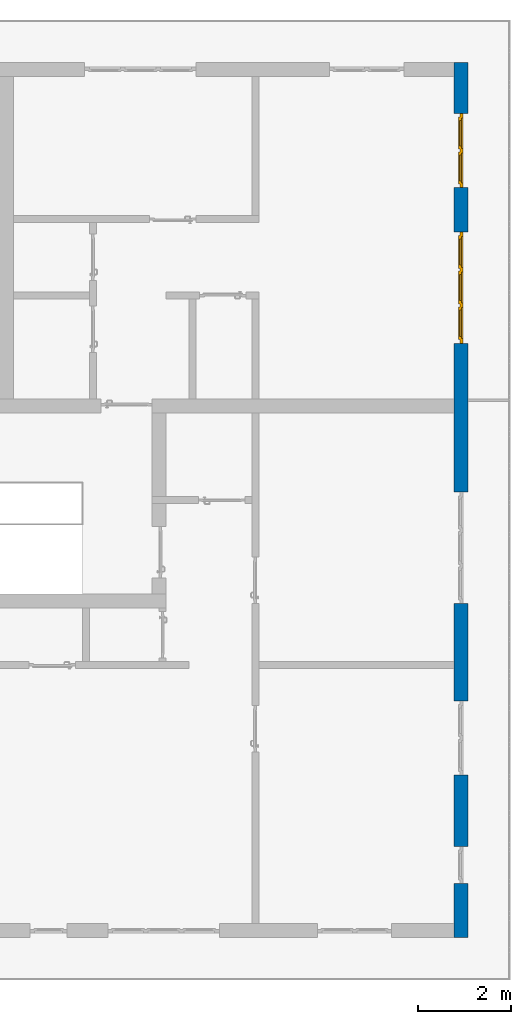
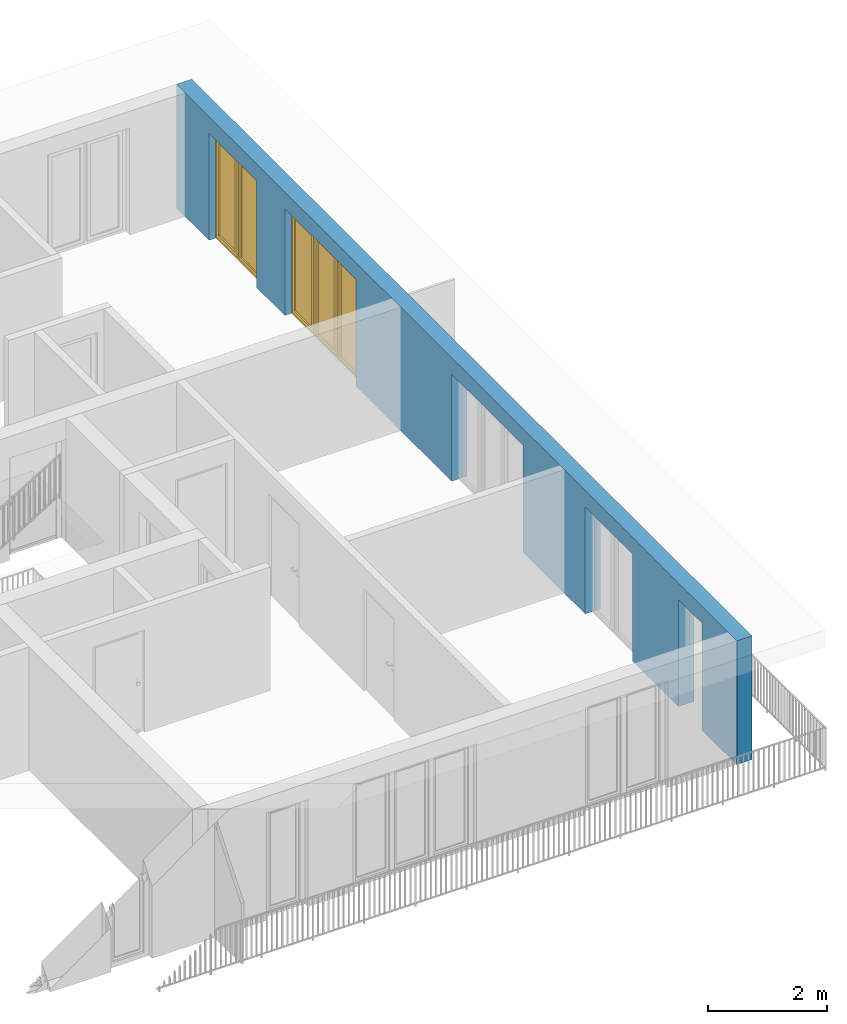
# One storey, part 20 of 54: 2 windows, 1 wall, 5 openings.
"""IFC4 building model written with IfcOpenShell, lengths in metres."""

from ifc_helpers import new_model, entity, si_unit, converted_unit, derived_unit, direction, frame, origin_with_axes, place, context, subcontext, project, spatial, polygons, source, transform, mapped, material, type_object, element, fill, save


model = new_model("IFC4")

# Units and contexts
model_context = context("Model", 3, precision=1e-05, world=origin_with_axes(), true_north=direction((0.0, 1.0)))
body_context = subcontext(model_context, "Body", "Model", "MODEL_VIEW")
ifc_project = project(units=[si_unit("LENGTHUNIT", "METRE"), si_unit("AREAUNIT", "SQUARE_METRE"), si_unit("VOLUMEUNIT", "CUBIC_METRE"), converted_unit("PLANEANGLEUNIT", "DEGREE", entity("IfcPlaneAngleMeasure", 0.0174532925199), si_unit("PLANEANGLEUNIT", "RADIAN"), dimensions=[0, 0, 0, 0, 0, 0, 0]), converted_unit("TIMEUNIT", "Year", entity("IfcTimeMeasure", 31556926.0), si_unit("TIMEUNIT", "SECOND"), dimensions=[0, 0, 1, 0, 0, 0, 0]), si_unit("MASSUNIT", "GRAM", prefix="KILO"), si_unit("THERMODYNAMICTEMPERATUREUNIT", "DEGREE_CELSIUS"), si_unit("LUMINOUSINTENSITYUNIT", "LUMEN"), si_unit("ENERGYUNIT", "JOULE", prefix="MEGA"), derived_unit("THERMALCONDUCTANCEUNIT", [(si_unit("POWERUNIT", "WATT"), 1), (si_unit("LENGTHUNIT", "METRE"), -1), (si_unit("THERMODYNAMICTEMPERATUREUNIT", "KELVIN"), -1)]), derived_unit("SPECIFICHEATCAPACITYUNIT", [(si_unit("ENERGYUNIT", "JOULE"), 1), (si_unit("MASSUNIT", "GRAM", prefix="KILO"), -1), (si_unit("THERMODYNAMICTEMPERATUREUNIT", "KELVIN"), -1)]), derived_unit("MASSDENSITYUNIT", [(si_unit("MASSUNIT", "GRAM", prefix="KILO"), 1), (si_unit("VOLUMEUNIT", "CUBIC_METRE"), -1)])], contexts=[model_context])

# Site, building, storey
site_placement = place(None, origin_with_axes())
site = spatial("IfcSite", under=ifc_project, at=site_placement, CompositionType="ELEMENT")
building_placement = place(site_placement, origin_with_axes())
building = spatial("IfcBuilding", under=site, at=building_placement, CompositionType="ELEMENT")
storey_placement = place(building_placement, frame((0.0, 0.0, 6.29), z_axis=(0.0, 0.0, 1.0), x_axis=(1.0, 0.0, 0.0)))
storey = spatial("IfcBuildingStorey", under=building, at=storey_placement, Name="2. Geschoss", CompositionType="ELEMENT", Elevation=6.29)

# Wall, openings, windows
ifc_material = material()
wall_type = type_object("IfcWallType", Name="300", PredefinedType="NOTDEFINED")
wall_placement = place(storey_placement, frame((9.3378006196, -9.92881223104, 0.0), z_axis=(0.0, 0.0, 1.0), x_axis=(0.0, 1.0, 0.0)))
wall = element("IfcWall", 1, at=wall_placement, inside=storey, type_object=wall_type, material=ifc_material, Name="Wand-001", PredefinedType="NOTDEFINED", context=body_context, shape_type="Tessellation", body=[
    polygons([(1.16441876325, 0.1, 2.2), (1.96441876325, 0.1, 2.2), (1.96441876325, 0.0, 2.2), (1.16441876325, 0.0, 2.2), (1.16441876325, 0.3, 2.2), (1.96441876325, 0.3, 2.2), (1.96441876325, 0.1, 0.0), (1.96441876325, 0.0, 0.0), (18.85, 0.0, 2.54), (0.0, 0.0, 2.54), (0.0, 0.0, 0.0), (1.16441876325, 0.0, 0.0), (3.5, 0.0, 0.0), (3.5, 0.0, 2.2), (5.1, 0.0, 2.2), (5.1, 0.0, 0.0), (7.1921181063, 0.0, 0.0), (7.1921181063, 0.0, 2.2), (9.5921181063, 0.0, 2.2), (9.5921181063, 0.0, 0.0), (12.8, 0.0, 0.0), (12.8, 0.0, 2.2), (15.2, 0.0, 2.2), (15.2, 0.0, 0.0), (16.15, 0.0, 0.0), (16.15, 0.0, 2.2), (17.75, 0.0, 2.2), (17.75, 0.0, 0.0), (18.85, 0.0, 0.0), (1.16441876325, 0.1, 0.0), (1.16441876325, 0.3, 0.0), (0.0, 0.3, 0.0), (0.0, 0.3, 2.54), (18.85, 0.3, 2.54), (18.85, 0.3, 0.0), (17.75, 0.3, 0.0), (17.75, 0.3, 2.2), (16.15, 0.3, 2.2), (16.15, 0.3, 0.0), (15.2, 0.3, 0.0), (15.2, 0.3, 2.2), (12.8, 0.3, 2.2), (12.8, 0.3, 0.0), (9.5921181063, 0.3, 0.0), (9.5921181063, 0.3, 2.2), (7.1921181063, 0.3, 2.2), (7.1921181063, 0.3, 0.0), (5.1, 0.3, 0.0), (5.1, 0.3, 2.2), (3.5, 0.3, 2.2), (3.5, 0.3, 0.0), (1.96441876325, 0.3, 0.0), (3.5, 0.1, 0.0), (3.5, 0.1, 2.2), (5.1, 0.1, 2.2), (5.1, 0.1, 0.0), (7.1921181063, 0.1, 0.0), (7.1921181063, 0.1, 2.2), (9.5921181063, 0.1, 2.2), (9.5921181063, 0.1, 0.0), (12.8, 0.1, 0.0), (12.8, 0.1, 2.2), (15.2, 0.1, 2.2), (15.2, 0.1, 0.0), (16.15, 0.1, 0.0), (16.15, 0.1, 2.2), (17.75, 0.1, 2.2), (17.75, 0.1, 0.0)], [[[1, 2, 3, 4]], [[2, 1, 5, 6]], [[2, 7, 8, 3]], [[9, 10, 11, 12, 4, 3, 8, 13, 14, 15, 16, 17, 18, 19, 20, 21, 22, 23, 24, 25, 26, 27, 28, 29]], [[30, 1, 4, 12]], [[1, 30, 31, 5]], [[5, 31, 32, 33, 34, 35, 36, 37, 38, 39, 40, 41, 42, 43, 44, 45, 46, 47, 48, 49, 50, 51, 52, 6]], [[7, 2, 6, 52]], [[7, 52, 51, 53, 13, 8]], [[9, 34, 33, 10]], [[33, 32, 11, 10]], [[31, 30, 12, 11, 32]], [[14, 13, 53, 54]], [[15, 14, 54, 55]], [[16, 15, 55, 56]], [[56, 48, 47, 57, 17, 16]], [[57, 58, 18, 17]], [[58, 59, 19, 18]], [[59, 60, 20, 19]], [[60, 44, 43, 61, 21, 20]], [[22, 21, 61, 62]], [[23, 22, 62, 63]], [[24, 23, 63, 64]], [[64, 40, 39, 65, 25, 24]], [[65, 66, 26, 25]], [[66, 67, 27, 26]], [[67, 68, 28, 27]], [[36, 35, 29, 28, 68]], [[9, 29, 35, 34]], [[68, 67, 37, 36]], [[67, 66, 38, 37]], [[66, 65, 39, 38]], [[41, 40, 64, 63]], [[42, 41, 63, 62]], [[43, 42, 62, 61]], [[60, 59, 45, 44]], [[59, 58, 46, 45]], [[58, 57, 47, 46]], [[49, 48, 56, 55]], [[50, 49, 55, 54]], [[51, 50, 54, 53]]], closed=True),
])
opening_1_placement = place(wall_placement, frame((16.95, 0.0, 0.0), z_axis=(0.0, 0.0, 1.0), x_axis=(1.0, 0.0, 0.0)))
opening_1 = element("IfcOpeningElement", 2, at=opening_1_placement, cuts=wall, Name="Fenster-001", context=body_context, identifier="Reference", shape_type="Tessellation", body=[
    polygons([(0.8, 0.1, 0.0), (0.8, 0.1, 2.2), (0.8, -0.000999999999999, 2.2), (0.8, -0.000999999999999, 0.0), (0.8, 0.301, 0.0), (0.8, 0.301, 2.2), (-0.8, 0.1, 2.2), (-0.8, -0.000999999999999, 2.2), (-0.8, 0.301, 2.2), (-0.8, -0.000999999999999, 0.0), (-0.8, 0.1, 0.0), (-0.8, 0.301, 0.0)], [[[1, 2, 3, 4]], [[2, 1, 5, 6]], [[7, 8, 3, 2, 6, 9]], [[8, 10, 4, 3]], [[1, 4, 10, 11, 12, 5]], [[6, 5, 12, 9]], [[7, 11, 10, 8]], [[11, 7, 9, 12]]], closed=True),
])
opening_2_placement = place(wall_placement, frame((14.0, 0.0, 0.0), z_axis=(0.0, 0.0, 1.0), x_axis=(1.0, 0.0, 0.0)))
opening_2 = element("IfcOpeningElement", 3, at=opening_2_placement, cuts=wall, Name="Fenster-002", context=body_context, identifier="Reference", shape_type="Tessellation", body=[
    polygons([(1.2, 0.1, 0.0), (1.2, 0.1, 2.2), (1.2, -0.000999999999999, 2.2), (1.2, -0.000999999999999, 0.0), (1.2, 0.301, 0.0), (1.2, 0.301, 2.2), (-1.2, 0.1, 2.2), (-1.2, -0.000999999999999, 2.2), (-1.2, 0.301, 2.2), (-1.2, -0.000999999999999, 0.0), (-1.2, 0.1, 0.0), (-1.2, 0.301, 0.0)], [[[1, 2, 3, 4]], [[2, 1, 5, 6]], [[7, 8, 3, 2, 6, 9]], [[8, 10, 4, 3]], [[1, 4, 10, 11, 12, 5]], [[6, 5, 12, 9]], [[7, 11, 10, 8]], [[11, 7, 9, 12]]], closed=True),
])
opening_3_placement = place(wall_placement, frame((8.3921181063, 0.0, 0.0), z_axis=(0.0, 0.0, 1.0), x_axis=(1.0, 0.0, 0.0)))
element("IfcOpeningElement", 4, at=opening_3_placement, cuts=wall, Name="Fenster-002", context=body_context, identifier="Reference", shape_type="Tessellation", body=[
    polygons([(1.2, 0.1, 0.0), (1.2, 0.1, 2.2), (1.2, -0.000999999999999, 2.2), (1.2, -0.000999999999999, 0.0), (1.2, 0.301, 0.0), (1.2, 0.301, 2.2), (-1.2, 0.1, 2.2), (-1.2, -0.000999999999999, 2.2), (-1.2, 0.301, 2.2), (-1.2, -0.000999999999999, 0.0), (-1.2, 0.1, 0.0), (-1.2, 0.301, 0.0)], [[[1, 2, 3, 4]], [[2, 1, 5, 6]], [[7, 8, 3, 2, 6, 9]], [[8, 10, 4, 3]], [[1, 4, 10, 11, 12, 5]], [[6, 5, 12, 9]], [[7, 11, 10, 8]], [[11, 7, 9, 12]]], closed=True),
])
opening_4_placement = place(wall_placement, frame((4.3, 0.0, 0.0), z_axis=(0.0, 0.0, 1.0), x_axis=(1.0, 0.0, 0.0)))
element("IfcOpeningElement", 5, at=opening_4_placement, cuts=wall, Name="Fenster-001", context=body_context, identifier="Reference", shape_type="Tessellation", body=[
    polygons([(0.8, 0.1, 0.0), (0.8, 0.1, 2.2), (0.8, -0.000999999999999, 2.2), (0.8, -0.000999999999999, 0.0), (0.8, 0.301, 0.0), (0.8, 0.301, 2.2), (-0.8, 0.1, 2.2), (-0.8, -0.000999999999999, 2.2), (-0.8, 0.301, 2.2), (-0.8, -0.000999999999999, 0.0), (-0.8, 0.1, 0.0), (-0.8, 0.301, 0.0)], [[[1, 2, 3, 4]], [[2, 1, 5, 6]], [[7, 8, 3, 2, 6, 9]], [[8, 10, 4, 3]], [[1, 4, 10, 11, 12, 5]], [[6, 5, 12, 9]], [[7, 11, 10, 8]], [[11, 7, 9, 12]]], closed=True),
])
opening_5_placement = place(wall_placement, frame((1.56441876325, 0.0, 0.0), z_axis=(0.0, 0.0, 1.0), x_axis=(1.0, 0.0, 0.0)))
element("IfcOpeningElement", 6, at=opening_5_placement, cuts=wall, Name="Fenster-003", context=body_context, identifier="Reference", shape_type="Tessellation", body=[
    polygons([(0.4, 0.1, 0.0), (0.4, 0.1, 2.2), (0.4, -0.000999999999999, 2.2), (0.4, -0.000999999999999, 0.0), (0.4, 0.301, 0.0), (0.4, 0.301, 2.2), (-0.4, 0.1, 2.2), (-0.4, -0.000999999999999, 2.2), (-0.4, 0.301, 2.2), (-0.4, -0.000999999999999, 0.0), (-0.4, 0.1, 0.0), (-0.4, 0.301, 0.0)], [[[1, 2, 3, 4]], [[2, 1, 5, 6]], [[7, 8, 3, 2, 6, 9]], [[8, 10, 4, 3]], [[1, 4, 10, 11, 12, 5]], [[6, 5, 12, 9]], [[7, 11, 10, 8]], [[11, 7, 9, 12]]], closed=True),
])
window_type_1 = type_object("IfcWindowType", Name="2-1+1 26", PartitioningType="DOUBLE_PANEL_VERTICAL", PredefinedType="WINDOW")
shared_shape_1 = source(origin_with_axes(), body_context, "Body", "Tessellation", [
    polygons([(-0.8, -0.07, 0.0), (-0.8, 0.0, 0.0), (-0.7, 0.0, 0.1), (-0.7, -0.07, 0.1), (-0.8, -0.07, 2.2), (-0.8, 0.0, 2.2), (-0.7, 0.0, 2.1), (-0.7, -0.07, 2.1)], [[[1, 2, 3, 4]], [[5, 6, 2, 1]], [[2, 6, 7, 3]], [[4, 3, 7, 8]], [[1, 4, 8, 5]], [[8, 7, 6, 5]]], closed=True),
    polygons([(0.8, -0.07, 0.0), (0.8, 0.0, 0.0), (0.8, 0.0, 2.2), (0.8, -0.07, 2.2), (0.7, -0.07, 0.1), (0.7, 0.0, 0.1), (0.7, 0.0, 2.1), (0.7, -0.07, 2.1)], [[[1, 2, 3, 4]], [[5, 6, 2, 1]], [[2, 6, 7, 3]], [[4, 3, 7, 8]], [[1, 4, 8, 5]], [[8, 7, 6, 5]]], closed=True),
    polygons([(-0.8, -0.07, 0.0), (-0.8, 0.0, 0.0), (0.8, 0.0, 0.0), (0.8, -0.07, 0.0), (-0.7, -0.07, 0.1), (-0.7, 0.0, 0.1), (-0.05, 0.0, 0.1), (0.05, 0.0, 0.1), (0.7, 0.0, 0.1), (0.7, -0.07, 0.1), (0.05, -0.07, 0.1), (-0.05, -0.07, 0.1)], [[[1, 2, 3, 4]], [[5, 6, 2, 1]], [[2, 6, 7, 8, 9, 3]], [[4, 3, 9, 10]], [[1, 4, 10, 11, 12, 5]], [[12, 7, 6, 5]], [[11, 8, 7, 12]], [[10, 9, 8, 11]]], closed=True),
    polygons([(-0.8, -0.07, 2.2), (-0.8, 0.0, 2.2), (-0.7, 0.0, 2.1), (-0.7, -0.07, 2.1), (0.8, -0.07, 2.2), (0.8, 0.0, 2.2), (0.7, 0.0, 2.1), (0.05, 0.0, 2.1), (-0.05, 0.0, 2.1), (-0.05, -0.07, 2.1), (0.05, -0.07, 2.1), (0.7, -0.07, 2.1)], [[[1, 2, 3, 4]], [[5, 6, 2, 1]], [[2, 6, 7, 8, 9, 3]], [[4, 3, 9, 10]], [[1, 4, 10, 11, 12, 5]], [[12, 7, 6, 5]], [[11, 8, 7, 12]], [[10, 9, 8, 11]]], closed=True),
    polygons([(-0.05, -0.07, 0.1), (-0.05, 0.0, 0.1), (0.05, 0.0, 0.1), (0.05, -0.07, 0.1), (-0.05, -0.07, 2.1), (-0.05, 0.0, 2.1), (0.05, 0.0, 2.1), (0.05, -0.07, 2.1)], [[[1, 2, 3, 4]], [[5, 6, 2, 1]], [[2, 6, 7, 3]], [[4, 3, 7, 8]], [[1, 4, 8, 5]], [[8, 7, 6, 5]]], closed=True),
    polygons([(-0.72, 0.0, 0.08), (-0.72, 0.03, 0.08), (-0.65, 0.03, 0.15), (-0.65, 0.0, 0.15), (-0.72, 0.0, 2.12), (-0.72, 0.03, 2.12), (-0.65, 0.03, 2.05), (-0.65, 0.0, 2.05)], [[[1, 2, 3, 4]], [[5, 6, 2, 1]], [[2, 6, 7, 3]], [[4, 3, 7, 8]], [[1, 4, 8, 5]], [[8, 7, 6, 5]]], closed=True),
    polygons([(-0.03, 0.0, 0.08), (-0.1, 0.0, 0.15), (-0.1, 0.03, 0.15), (-0.03, 0.03, 0.08), (-0.03, 0.0, 2.12), (-0.1, 0.0, 2.05), (-0.1, 0.03, 2.05), (-0.03, 0.03, 2.12)], [[[1, 2, 3, 4]], [[1, 5, 6, 2]], [[2, 6, 7, 3]], [[4, 3, 7, 8]], [[5, 1, 4, 8]], [[6, 5, 8, 7]]], closed=True),
    polygons([(-0.72, 0.0, 0.08), (-0.72, 0.03, 0.08), (-0.03, 0.03, 0.08), (-0.03, 0.0, 0.08), (-0.65, 0.0, 0.15), (-0.65, 0.03, 0.15), (-0.1, 0.03, 0.15), (-0.1, 0.0, 0.15)], [[[1, 2, 3, 4]], [[5, 6, 2, 1]], [[2, 6, 7, 3]], [[4, 3, 7, 8]], [[1, 4, 8, 5]], [[8, 7, 6, 5]]], closed=True),
    polygons([(-0.72, 0.0, 2.12), (-0.03, 0.0, 2.12), (-0.03, 0.03, 2.12), (-0.72, 0.03, 2.12), (-0.65, 0.0, 2.05), (-0.1, 0.0, 2.05), (-0.1, 0.03, 2.05), (-0.65, 0.03, 2.05)], [[[1, 2, 3, 4]], [[1, 5, 6, 2]], [[2, 6, 7, 3]], [[4, 3, 7, 8]], [[5, 1, 4, 8]], [[6, 5, 8, 7]]], closed=True),
    polygons([(-0.7, -0.03, 0.1), (-0.7, 0.0, 0.1), (-0.65, 0.0, 0.15), (-0.65, -0.03, 0.15), (-0.7, -0.03, 2.1), (-0.7, 0.0, 2.1), (-0.65, 0.0, 2.05), (-0.65, -0.03, 2.05)], [[[1, 2, 3, 4]], [[5, 6, 2, 1]], [[2, 6, 7, 3]], [[4, 3, 7, 8]], [[1, 4, 8, 5]], [[8, 7, 6, 5]]], closed=True),
    polygons([(-0.05, -0.03, 0.1), (-0.1, -0.03, 0.15), (-0.1, 0.0, 0.15), (-0.05, 0.0, 0.1), (-0.05, -0.03, 2.1), (-0.1, -0.03, 2.05), (-0.1, 0.0, 2.05), (-0.05, 0.0, 2.1)], [[[1, 2, 3, 4]], [[1, 5, 6, 2]], [[2, 6, 7, 3]], [[4, 3, 7, 8]], [[5, 1, 4, 8]], [[6, 5, 8, 7]]], closed=True),
    polygons([(-0.7, -0.03, 0.1), (-0.7, 0.0, 0.1), (-0.05, 0.0, 0.1), (-0.05, -0.03, 0.1), (-0.65, -0.03, 0.15), (-0.65, 0.0, 0.15), (-0.1, 0.0, 0.15), (-0.1, -0.03, 0.15)], [[[1, 2, 3, 4]], [[5, 6, 2, 1]], [[2, 6, 7, 3]], [[4, 3, 7, 8]], [[1, 4, 8, 5]], [[8, 7, 6, 5]]], closed=True),
    polygons([(-0.7, -0.03, 2.1), (-0.05, -0.03, 2.1), (-0.05, 0.0, 2.1), (-0.7, 0.0, 2.1), (-0.65, -0.03, 2.05), (-0.1, -0.03, 2.05), (-0.1, 0.0, 2.05), (-0.65, 0.0, 2.05)], [[[1, 2, 3, 4]], [[1, 5, 6, 2]], [[2, 6, 7, 3]], [[4, 3, 7, 8]], [[5, 1, 4, 8]], [[6, 5, 8, 7]]], closed=True),
    polygons([(-0.65, -0.005, 0.15), (-0.65, 0.005, 0.15), (-0.1, 0.005, 0.15), (-0.1, -0.005, 0.15), (-0.65, -0.005, 2.05), (-0.65, 0.005, 2.05), (-0.1, 0.005, 2.05), (-0.1, -0.005, 2.05)], [[[1, 2, 3, 4]], [[5, 6, 2, 1]], [[2, 6, 7, 3]], [[4, 3, 7, 8]], [[1, 4, 8, 5]], [[8, 7, 6, 5]]], closed=True),
    polygons([(0.03, 0.0, 0.08), (0.03, 0.03, 0.08), (0.1, 0.03, 0.15), (0.1, 0.0, 0.15), (0.03, 0.0, 2.12), (0.03, 0.03, 2.12), (0.1, 0.03, 2.05), (0.1, 0.0, 2.05)], [[[1, 2, 3, 4]], [[5, 6, 2, 1]], [[2, 6, 7, 3]], [[4, 3, 7, 8]], [[1, 4, 8, 5]], [[8, 7, 6, 5]]], closed=True),
    polygons([(0.72, 0.0, 0.08), (0.65, 0.0, 0.15), (0.65, 0.03, 0.15), (0.72, 0.03, 0.08), (0.72, 0.0, 2.12), (0.65, 0.0, 2.05), (0.65, 0.03, 2.05), (0.72, 0.03, 2.12)], [[[1, 2, 3, 4]], [[1, 5, 6, 2]], [[2, 6, 7, 3]], [[4, 3, 7, 8]], [[5, 1, 4, 8]], [[6, 5, 8, 7]]], closed=True),
    polygons([(0.03, 0.0, 0.08), (0.03, 0.03, 0.08), (0.72, 0.03, 0.08), (0.72, 0.0, 0.08), (0.1, 0.0, 0.15), (0.1, 0.03, 0.15), (0.65, 0.03, 0.15), (0.65, 0.0, 0.15)], [[[1, 2, 3, 4]], [[5, 6, 2, 1]], [[2, 6, 7, 3]], [[4, 3, 7, 8]], [[1, 4, 8, 5]], [[8, 7, 6, 5]]], closed=True),
    polygons([(0.03, 0.0, 2.12), (0.72, 0.0, 2.12), (0.72, 0.03, 2.12), (0.03, 0.03, 2.12), (0.1, 0.0, 2.05), (0.65, 0.0, 2.05), (0.65, 0.03, 2.05), (0.1, 0.03, 2.05)], [[[1, 2, 3, 4]], [[1, 5, 6, 2]], [[2, 6, 7, 3]], [[4, 3, 7, 8]], [[5, 1, 4, 8]], [[6, 5, 8, 7]]], closed=True),
    polygons([(0.05, -0.03, 0.1), (0.05, 0.0, 0.1), (0.1, 0.0, 0.15), (0.1, -0.03, 0.15), (0.05, -0.03, 2.1), (0.05, 0.0, 2.1), (0.1, 0.0, 2.05), (0.1, -0.03, 2.05)], [[[1, 2, 3, 4]], [[5, 6, 2, 1]], [[2, 6, 7, 3]], [[4, 3, 7, 8]], [[1, 4, 8, 5]], [[8, 7, 6, 5]]], closed=True),
    polygons([(0.7, -0.03, 0.1), (0.65, -0.03, 0.15), (0.65, 0.0, 0.15), (0.7, 0.0, 0.1), (0.7, -0.03, 2.1), (0.65, -0.03, 2.05), (0.65, 0.0, 2.05), (0.7, 0.0, 2.1)], [[[1, 2, 3, 4]], [[1, 5, 6, 2]], [[2, 6, 7, 3]], [[4, 3, 7, 8]], [[5, 1, 4, 8]], [[6, 5, 8, 7]]], closed=True),
    polygons([(0.05, -0.03, 0.1), (0.05, 0.0, 0.1), (0.7, 0.0, 0.1), (0.7, -0.03, 0.1), (0.1, -0.03, 0.15), (0.1, 0.0, 0.15), (0.65, 0.0, 0.15), (0.65, -0.03, 0.15)], [[[1, 2, 3, 4]], [[5, 6, 2, 1]], [[2, 6, 7, 3]], [[4, 3, 7, 8]], [[1, 4, 8, 5]], [[8, 7, 6, 5]]], closed=True),
    polygons([(0.05, -0.03, 2.1), (0.7, -0.03, 2.1), (0.7, 0.0, 2.1), (0.05, 0.0, 2.1), (0.1, -0.03, 2.05), (0.65, -0.03, 2.05), (0.65, 0.0, 2.05), (0.1, 0.0, 2.05)], [[[1, 2, 3, 4]], [[1, 5, 6, 2]], [[2, 6, 7, 3]], [[4, 3, 7, 8]], [[5, 1, 4, 8]], [[6, 5, 8, 7]]], closed=True),
    polygons([(0.1, -0.005, 0.15), (0.1, 0.005, 0.15), (0.65, 0.005, 0.15), (0.65, -0.005, 0.15), (0.1, -0.005, 2.05), (0.1, 0.005, 2.05), (0.65, 0.005, 2.05), (0.65, -0.005, 2.05)], [[[1, 2, 3, 4]], [[5, 6, 2, 1]], [[2, 6, 7, 3]], [[4, 3, 7, 8]], [[1, 4, 8, 5]], [[8, 7, 6, 5]]], closed=True),
])
window_1_placement = place(opening_1_placement, frame((-0.8, 0.0, 0.0), z_axis=(0.0, 0.0, 1.0), x_axis=(1.0, 0.0, 0.0)))
window_1 = element("IfcWindow", 7, at=window_1_placement, inside=storey, type_object=window_type_1, Name="Fenster-001", OverallHeight=2.2, OverallWidth=1.6, PredefinedType="WINDOW", context=body_context, shape_type="MappedRepresentation", body=[
    mapped(shared_shape_1, transform((0.8, 0.17, 0.0))),
])
fill(opening_1, window_1)
window_type_2 = type_object("IfcWindowType", Name="3-1+1+1 26", PartitioningType="TRIPLE_PANEL_VERTICAL", PredefinedType="WINDOW")
shared_shape_2 = source(origin_with_axes(), body_context, "Body", "Tessellation", [
    polygons([(1.2, -0.07, 0.0), (1.1, -0.07, 0.1), (1.1, 0.0, 0.1), (1.2, 0.0, 0.0), (1.2, -0.07, 2.2), (1.1, -0.07, 2.1), (1.1, 0.0, 2.1), (1.2, 0.0, 2.2)], [[[1, 2, 3, 4]], [[1, 5, 6, 2]], [[2, 6, 7, 3]], [[4, 3, 7, 8]], [[5, 1, 4, 8]], [[6, 5, 8, 7]]], closed=True),
    polygons([(-1.2, -0.07, 0.0), (-1.2, -0.07, 2.2), (-1.2, 0.0, 2.2), (-1.2, 0.0, 0.0), (-1.1, -0.07, 0.1), (-1.1, -0.07, 2.1), (-1.1, 0.0, 2.1), (-1.1, 0.0, 0.1)], [[[1, 2, 3, 4]], [[1, 5, 6, 2]], [[2, 6, 7, 3]], [[4, 3, 7, 8]], [[5, 1, 4, 8]], [[6, 5, 8, 7]]], closed=True),
    polygons([(1.2, -0.07, 0.0), (-1.2, -0.07, 0.0), (-1.2, 0.0, 0.0), (1.2, 0.0, 0.0), (1.1, -0.07, 0.1), (0.433333333333, -0.07, 0.1), (0.333333333333, -0.07, 0.1), (-0.333333333333, -0.07, 0.1), (-0.433333333333, -0.07, 0.1), (-1.1, -0.07, 0.1), (-1.1, 0.0, 0.1), (-0.433333333333, 0.0, 0.1), (-0.333333333333, 0.0, 0.1), (0.333333333333, 0.0, 0.1), (0.433333333333, 0.0, 0.1), (1.1, 0.0, 0.1)], [[[1, 2, 3, 4]], [[1, 5, 6, 7, 8, 9, 10, 2]], [[2, 10, 11, 3]], [[4, 3, 11, 12, 13, 14, 15, 16]], [[5, 1, 4, 16]], [[6, 5, 16, 15]], [[7, 6, 15, 14]], [[8, 7, 14, 13]], [[9, 8, 13, 12]], [[10, 9, 12, 11]]], closed=True),
    polygons([(1.2, -0.07, 2.2), (1.1, -0.07, 2.1), (1.1, 0.0, 2.1), (1.2, 0.0, 2.2), (-1.2, -0.07, 2.2), (-1.1, -0.07, 2.1), (-0.433333333333, -0.07, 2.1), (-0.333333333333, -0.07, 2.1), (0.333333333333, -0.07, 2.1), (0.433333333333, -0.07, 2.1), (0.433333333333, 0.0, 2.1), (0.333333333333, 0.0, 2.1), (-0.333333333333, 0.0, 2.1), (-0.433333333333, 0.0, 2.1), (-1.1, 0.0, 2.1), (-1.2, 0.0, 2.2)], [[[1, 2, 3, 4]], [[1, 5, 6, 7, 8, 9, 10, 2]], [[2, 10, 11, 3]], [[4, 3, 11, 12, 13, 14, 15, 16]], [[5, 1, 4, 16]], [[6, 5, 16, 15]], [[7, 6, 15, 14]], [[8, 7, 14, 13]], [[9, 8, 13, 12]], [[10, 9, 12, 11]]], closed=True),
    polygons([(-0.333333333333, -0.07, 0.1), (-0.433333333333, -0.07, 0.1), (-0.433333333333, 0.0, 0.1), (-0.333333333333, 0.0, 0.1), (-0.333333333333, -0.07, 2.1), (-0.433333333333, -0.07, 2.1), (-0.433333333333, 0.0, 2.1), (-0.333333333333, 0.0, 2.1)], [[[1, 2, 3, 4]], [[1, 5, 6, 2]], [[2, 6, 7, 3]], [[4, 3, 7, 8]], [[5, 1, 4, 8]], [[6, 5, 8, 7]]], closed=True),
    polygons([(0.433333333333, -0.07, 0.1), (0.333333333333, -0.07, 0.1), (0.333333333333, 0.0, 0.1), (0.433333333333, 0.0, 0.1), (0.433333333333, -0.07, 2.1), (0.333333333333, -0.07, 2.1), (0.333333333333, 0.0, 2.1), (0.433333333333, 0.0, 2.1)], [[[1, 2, 3, 4]], [[1, 5, 6, 2]], [[2, 6, 7, 3]], [[4, 3, 7, 8]], [[5, 1, 4, 8]], [[6, 5, 8, 7]]], closed=True),
    polygons([(1.12, 0.0, 0.08), (1.05, 0.0, 0.15), (1.05, 0.03, 0.15), (1.12, 0.03, 0.08), (1.12, 0.0, 2.12), (1.05, 0.0, 2.05), (1.05, 0.03, 2.05), (1.12, 0.03, 2.12)], [[[1, 2, 3, 4]], [[1, 5, 6, 2]], [[2, 6, 7, 3]], [[4, 3, 7, 8]], [[5, 1, 4, 8]], [[6, 5, 8, 7]]], closed=True),
    polygons([(0.413333333333, 0.0, 0.08), (0.413333333333, 0.03, 0.08), (0.483333333333, 0.03, 0.15), (0.483333333333, 0.0, 0.15), (0.413333333333, 0.0, 2.12), (0.413333333333, 0.03, 2.12), (0.483333333333, 0.03, 2.05), (0.483333333333, 0.0, 2.05)], [[[1, 2, 3, 4]], [[5, 6, 2, 1]], [[2, 6, 7, 3]], [[4, 3, 7, 8]], [[1, 4, 8, 5]], [[8, 7, 6, 5]]], closed=True),
    polygons([(1.12, 0.0, 0.08), (0.413333333333, 0.0, 0.08), (0.413333333333, 0.03, 0.08), (1.12, 0.03, 0.08), (1.05, 0.0, 0.15), (0.483333333333, 0.0, 0.15), (0.483333333333, 0.03, 0.15), (1.05, 0.03, 0.15)], [[[1, 2, 3, 4]], [[1, 5, 6, 2]], [[2, 6, 7, 3]], [[4, 3, 7, 8]], [[5, 1, 4, 8]], [[6, 5, 8, 7]]], closed=True),
    polygons([(1.12, 0.0, 2.12), (1.12, 0.03, 2.12), (0.413333333333, 0.03, 2.12), (0.413333333333, 0.0, 2.12), (1.05, 0.0, 2.05), (1.05, 0.03, 2.05), (0.483333333333, 0.03, 2.05), (0.483333333333, 0.0, 2.05)], [[[1, 2, 3, 4]], [[5, 6, 2, 1]], [[2, 6, 7, 3]], [[4, 3, 7, 8]], [[1, 4, 8, 5]], [[8, 7, 6, 5]]], closed=True),
    polygons([(1.1, -0.03, 0.1), (1.05, -0.03, 0.15), (1.05, 0.0, 0.15), (1.1, 0.0, 0.1), (1.1, -0.03, 2.1), (1.05, -0.03, 2.05), (1.05, 0.0, 2.05), (1.1, 0.0, 2.1)], [[[1, 2, 3, 4]], [[1, 5, 6, 2]], [[2, 6, 7, 3]], [[4, 3, 7, 8]], [[5, 1, 4, 8]], [[6, 5, 8, 7]]], closed=True),
    polygons([(0.433333333333, -0.03, 0.1), (0.433333333333, 0.0, 0.1), (0.483333333333, 0.0, 0.15), (0.483333333333, -0.03, 0.15), (0.433333333333, -0.03, 2.1), (0.433333333333, 0.0, 2.1), (0.483333333333, 0.0, 2.05), (0.483333333333, -0.03, 2.05)], [[[1, 2, 3, 4]], [[5, 6, 2, 1]], [[2, 6, 7, 3]], [[4, 3, 7, 8]], [[1, 4, 8, 5]], [[8, 7, 6, 5]]], closed=True),
    polygons([(1.1, -0.03, 0.1), (0.433333333333, -0.03, 0.1), (0.433333333333, 0.0, 0.1), (1.1, 0.0, 0.1), (1.05, -0.03, 0.15), (0.483333333333, -0.03, 0.15), (0.483333333333, 0.0, 0.15), (1.05, 0.0, 0.15)], [[[1, 2, 3, 4]], [[1, 5, 6, 2]], [[2, 6, 7, 3]], [[4, 3, 7, 8]], [[5, 1, 4, 8]], [[6, 5, 8, 7]]], closed=True),
    polygons([(1.1, -0.03, 2.1), (1.1, 0.0, 2.1), (0.433333333333, 0.0, 2.1), (0.433333333333, -0.03, 2.1), (1.05, -0.03, 2.05), (1.05, 0.0, 2.05), (0.483333333333, 0.0, 2.05), (0.483333333333, -0.03, 2.05)], [[[1, 2, 3, 4]], [[5, 6, 2, 1]], [[2, 6, 7, 3]], [[4, 3, 7, 8]], [[1, 4, 8, 5]], [[8, 7, 6, 5]]], closed=True),
    polygons([(1.05, -0.005, 0.15), (0.483333333333, -0.005, 0.15), (0.483333333333, 0.005, 0.15), (1.05, 0.005, 0.15), (1.05, -0.005, 2.05), (0.483333333333, -0.005, 2.05), (0.483333333333, 0.005, 2.05), (1.05, 0.005, 2.05)], [[[1, 2, 3, 4]], [[1, 5, 6, 2]], [[2, 6, 7, 3]], [[4, 3, 7, 8]], [[5, 1, 4, 8]], [[6, 5, 8, 7]]], closed=True),
    polygons([(0.353333333333, 0.0, 0.08), (0.283333333333, 0.0, 0.15), (0.283333333333, 0.03, 0.15), (0.353333333333, 0.03, 0.08), (0.353333333333, 0.0, 2.12), (0.283333333333, 0.0, 2.05), (0.283333333333, 0.03, 2.05), (0.353333333333, 0.03, 2.12)], [[[1, 2, 3, 4]], [[1, 5, 6, 2]], [[2, 6, 7, 3]], [[4, 3, 7, 8]], [[5, 1, 4, 8]], [[6, 5, 8, 7]]], closed=True),
    polygons([(-0.353333333333, 0.0, 0.08), (-0.353333333333, 0.03, 0.08), (-0.283333333333, 0.03, 0.15), (-0.283333333333, 0.0, 0.15), (-0.353333333333, 0.0, 2.12), (-0.353333333333, 0.03, 2.12), (-0.283333333333, 0.03, 2.05), (-0.283333333333, 0.0, 2.05)], [[[1, 2, 3, 4]], [[5, 6, 2, 1]], [[2, 6, 7, 3]], [[4, 3, 7, 8]], [[1, 4, 8, 5]], [[8, 7, 6, 5]]], closed=True),
    polygons([(0.353333333333, 0.0, 0.08), (-0.353333333333, 0.0, 0.08), (-0.353333333333, 0.03, 0.08), (0.353333333333, 0.03, 0.08), (0.283333333333, 0.0, 0.15), (-0.283333333333, 0.0, 0.15), (-0.283333333333, 0.03, 0.15), (0.283333333333, 0.03, 0.15)], [[[1, 2, 3, 4]], [[1, 5, 6, 2]], [[2, 6, 7, 3]], [[4, 3, 7, 8]], [[5, 1, 4, 8]], [[6, 5, 8, 7]]], closed=True),
    polygons([(0.353333333333, 0.0, 2.12), (0.353333333333, 0.03, 2.12), (-0.353333333333, 0.03, 2.12), (-0.353333333333, 0.0, 2.12), (0.283333333333, 0.0, 2.05), (0.283333333333, 0.03, 2.05), (-0.283333333333, 0.03, 2.05), (-0.283333333333, 0.0, 2.05)], [[[1, 2, 3, 4]], [[5, 6, 2, 1]], [[2, 6, 7, 3]], [[4, 3, 7, 8]], [[1, 4, 8, 5]], [[8, 7, 6, 5]]], closed=True),
    polygons([(0.333333333333, -0.03, 0.1), (0.283333333333, -0.03, 0.15), (0.283333333333, 0.0, 0.15), (0.333333333333, 0.0, 0.1), (0.333333333333, -0.03, 2.1), (0.283333333333, -0.03, 2.05), (0.283333333333, 0.0, 2.05), (0.333333333333, 0.0, 2.1)], [[[1, 2, 3, 4]], [[1, 5, 6, 2]], [[2, 6, 7, 3]], [[4, 3, 7, 8]], [[5, 1, 4, 8]], [[6, 5, 8, 7]]], closed=True),
    polygons([(-0.333333333333, -0.03, 0.1), (-0.333333333333, 0.0, 0.1), (-0.283333333333, 0.0, 0.15), (-0.283333333333, -0.03, 0.15), (-0.333333333333, -0.03, 2.1), (-0.333333333333, 0.0, 2.1), (-0.283333333333, 0.0, 2.05), (-0.283333333333, -0.03, 2.05)], [[[1, 2, 3, 4]], [[5, 6, 2, 1]], [[2, 6, 7, 3]], [[4, 3, 7, 8]], [[1, 4, 8, 5]], [[8, 7, 6, 5]]], closed=True),
    polygons([(0.333333333333, -0.03, 0.1), (-0.333333333333, -0.03, 0.1), (-0.333333333333, 0.0, 0.1), (0.333333333333, 0.0, 0.1), (0.283333333333, -0.03, 0.15), (-0.283333333333, -0.03, 0.15), (-0.283333333333, 0.0, 0.15), (0.283333333333, 0.0, 0.15)], [[[1, 2, 3, 4]], [[1, 5, 6, 2]], [[2, 6, 7, 3]], [[4, 3, 7, 8]], [[5, 1, 4, 8]], [[6, 5, 8, 7]]], closed=True),
    polygons([(0.333333333333, -0.03, 2.1), (0.333333333333, 0.0, 2.1), (-0.333333333333, 0.0, 2.1), (-0.333333333333, -0.03, 2.1), (0.283333333333, -0.03, 2.05), (0.283333333333, 0.0, 2.05), (-0.283333333333, 0.0, 2.05), (-0.283333333333, -0.03, 2.05)], [[[1, 2, 3, 4]], [[5, 6, 2, 1]], [[2, 6, 7, 3]], [[4, 3, 7, 8]], [[1, 4, 8, 5]], [[8, 7, 6, 5]]], closed=True),
    polygons([(0.283333333333, -0.005, 0.15), (-0.283333333333, -0.005, 0.15), (-0.283333333333, 0.005, 0.15), (0.283333333333, 0.005, 0.15), (0.283333333333, -0.005, 2.05), (-0.283333333333, -0.005, 2.05), (-0.283333333333, 0.005, 2.05), (0.283333333333, 0.005, 2.05)], [[[1, 2, 3, 4]], [[1, 5, 6, 2]], [[2, 6, 7, 3]], [[4, 3, 7, 8]], [[5, 1, 4, 8]], [[6, 5, 8, 7]]], closed=True),
    polygons([(-0.413333333333, 0.0, 0.08), (-0.483333333333, 0.0, 0.15), (-0.483333333333, 0.03, 0.15), (-0.413333333333, 0.03, 0.08), (-0.413333333333, 0.0, 2.12), (-0.483333333333, 0.0, 2.05), (-0.483333333333, 0.03, 2.05), (-0.413333333333, 0.03, 2.12)], [[[1, 2, 3, 4]], [[1, 5, 6, 2]], [[2, 6, 7, 3]], [[4, 3, 7, 8]], [[5, 1, 4, 8]], [[6, 5, 8, 7]]], closed=True),
    polygons([(-1.12, 0.0, 0.08), (-1.12, 0.03, 0.08), (-1.05, 0.03, 0.15), (-1.05, 0.0, 0.15), (-1.12, 0.0, 2.12), (-1.12, 0.03, 2.12), (-1.05, 0.03, 2.05), (-1.05, 0.0, 2.05)], [[[1, 2, 3, 4]], [[5, 6, 2, 1]], [[2, 6, 7, 3]], [[4, 3, 7, 8]], [[1, 4, 8, 5]], [[8, 7, 6, 5]]], closed=True),
    polygons([(-0.413333333333, 0.0, 0.08), (-1.12, 0.0, 0.08), (-1.12, 0.03, 0.08), (-0.413333333333, 0.03, 0.08), (-0.483333333333, 0.0, 0.15), (-1.05, 0.0, 0.15), (-1.05, 0.03, 0.15), (-0.483333333333, 0.03, 0.15)], [[[1, 2, 3, 4]], [[1, 5, 6, 2]], [[2, 6, 7, 3]], [[4, 3, 7, 8]], [[5, 1, 4, 8]], [[6, 5, 8, 7]]], closed=True),
    polygons([(-0.413333333333, 0.0, 2.12), (-0.413333333333, 0.03, 2.12), (-1.12, 0.03, 2.12), (-1.12, 0.0, 2.12), (-0.483333333333, 0.0, 2.05), (-0.483333333333, 0.03, 2.05), (-1.05, 0.03, 2.05), (-1.05, 0.0, 2.05)], [[[1, 2, 3, 4]], [[5, 6, 2, 1]], [[2, 6, 7, 3]], [[4, 3, 7, 8]], [[1, 4, 8, 5]], [[8, 7, 6, 5]]], closed=True),
    polygons([(-0.433333333333, -0.03, 0.1), (-0.483333333333, -0.03, 0.15), (-0.483333333333, 0.0, 0.15), (-0.433333333333, 0.0, 0.1), (-0.433333333333, -0.03, 2.1), (-0.483333333333, -0.03, 2.05), (-0.483333333333, 0.0, 2.05), (-0.433333333333, 0.0, 2.1)], [[[1, 2, 3, 4]], [[1, 5, 6, 2]], [[2, 6, 7, 3]], [[4, 3, 7, 8]], [[5, 1, 4, 8]], [[6, 5, 8, 7]]], closed=True),
    polygons([(-1.1, -0.03, 0.1), (-1.1, 0.0, 0.1), (-1.05, 0.0, 0.15), (-1.05, -0.03, 0.15), (-1.1, -0.03, 2.1), (-1.1, 0.0, 2.1), (-1.05, 0.0, 2.05), (-1.05, -0.03, 2.05)], [[[1, 2, 3, 4]], [[5, 6, 2, 1]], [[2, 6, 7, 3]], [[4, 3, 7, 8]], [[1, 4, 8, 5]], [[8, 7, 6, 5]]], closed=True),
    polygons([(-0.433333333333, -0.03, 0.1), (-1.1, -0.03, 0.1), (-1.1, 0.0, 0.1), (-0.433333333333, 0.0, 0.1), (-0.483333333333, -0.03, 0.15), (-1.05, -0.03, 0.15), (-1.05, 0.0, 0.15), (-0.483333333333, 0.0, 0.15)], [[[1, 2, 3, 4]], [[1, 5, 6, 2]], [[2, 6, 7, 3]], [[4, 3, 7, 8]], [[5, 1, 4, 8]], [[6, 5, 8, 7]]], closed=True),
    polygons([(-0.433333333333, -0.03, 2.1), (-0.433333333333, 0.0, 2.1), (-1.1, 0.0, 2.1), (-1.1, -0.03, 2.1), (-0.483333333333, -0.03, 2.05), (-0.483333333333, 0.0, 2.05), (-1.05, 0.0, 2.05), (-1.05, -0.03, 2.05)], [[[1, 2, 3, 4]], [[5, 6, 2, 1]], [[2, 6, 7, 3]], [[4, 3, 7, 8]], [[1, 4, 8, 5]], [[8, 7, 6, 5]]], closed=True),
    polygons([(-0.483333333333, -0.005, 0.15), (-1.05, -0.005, 0.15), (-1.05, 0.005, 0.15), (-0.483333333333, 0.005, 0.15), (-0.483333333333, -0.005, 2.05), (-1.05, -0.005, 2.05), (-1.05, 0.005, 2.05), (-0.483333333333, 0.005, 2.05)], [[[1, 2, 3, 4]], [[1, 5, 6, 2]], [[2, 6, 7, 3]], [[4, 3, 7, 8]], [[5, 1, 4, 8]], [[6, 5, 8, 7]]], closed=True),
])
window_2_placement = place(opening_2_placement, frame((-1.2, 0.0, 0.0), z_axis=(0.0, 0.0, 1.0), x_axis=(1.0, 0.0, 0.0)))
window_2 = element("IfcWindow", 8, at=window_2_placement, inside=storey, type_object=window_type_2, Name="Fenster-002", OverallHeight=2.2, OverallWidth=2.4, PredefinedType="WINDOW", context=body_context, shape_type="MappedRepresentation", body=[
    mapped(shared_shape_2, transform((1.2, 0.17, 0.0))),
])
fill(opening_2, window_2)

save(model, "model.ifc")
